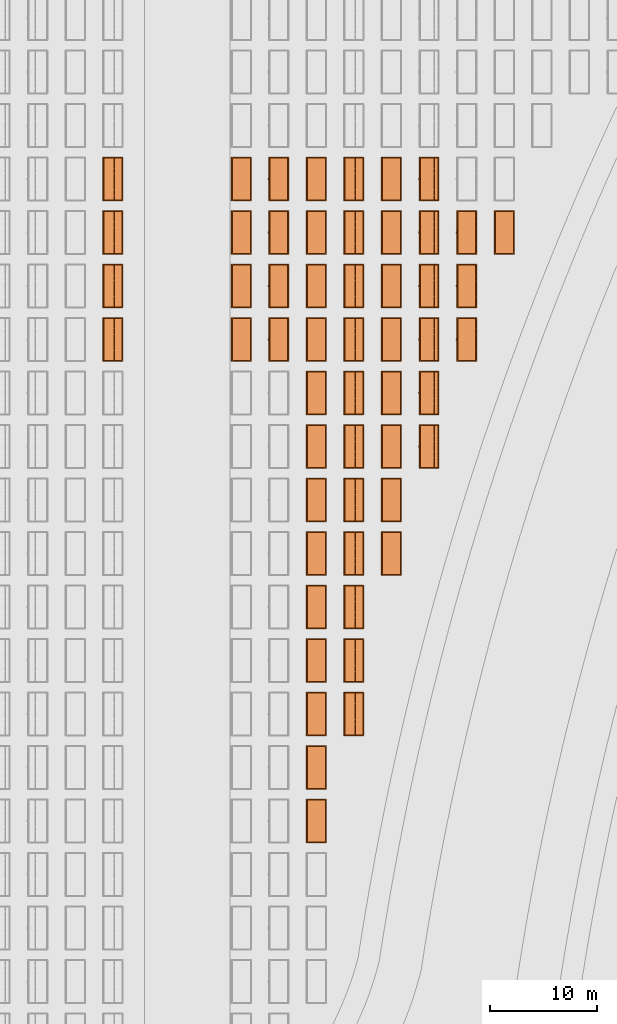
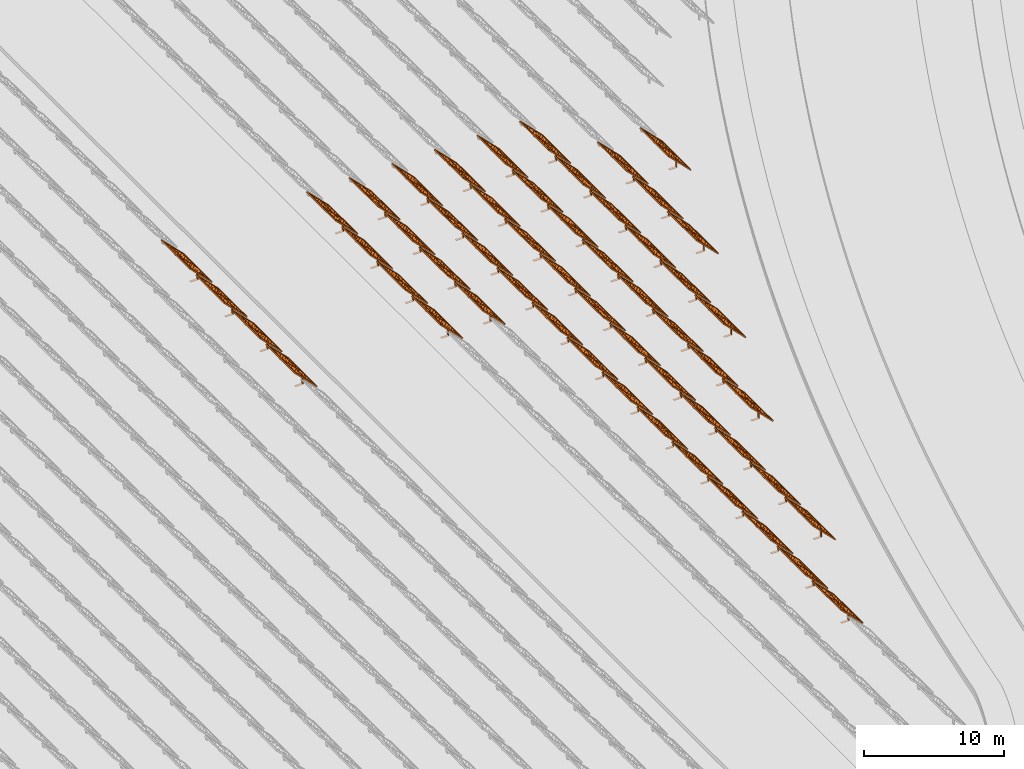
# One storey, part 26 of 39: 54 proxies.
"""IFC2X3 building model written with IfcOpenShell, lengths in millimetres."""

from ifc_helpers import new_model, entity, si_unit, converted_unit, derived_unit, direction, frame, frame_2d, origin, origin_2d_with_axis, place, context, subcontext, project, spatial, polyline, rectangle, outline, extrude, source, transform, mapped, material, material_list, element, save


model = new_model("IFC2X3")

# Units and contexts
model_context = context("Model", 3, precision=1e-06, world=origin(), true_north=direction((2.0, 6.12303176911189e-17, 1.0)))
context_of_model = context(None, 3, precision=1e-06, world=origin(), true_north=direction((2.0, 6.12303176911189e-17, 1.0)))
body_context = subcontext(model_context, "Body", "Model", "MODEL_VIEW")
ifc_project = project(units=[si_unit("LENGTHUNIT", "METRE", prefix="MILLI"), si_unit("AREAUNIT", "SQUARE_METRE", prefix="MILLI"), si_unit("VOLUMEUNIT", "CUBIC_METRE", prefix="MILLI"), converted_unit("PLANEANGLEUNIT", "DEGREE", entity("IfcRatioMeasure", 0.0174532925199433), si_unit("PLANEANGLEUNIT", "RADIAN"), dimensions=[0, 0, 0, 0, 0, 0, 0]), si_unit("MASSUNIT", "GRAM", prefix="KILO"), si_unit("TIMEUNIT", "SECOND"), si_unit("THERMODYNAMICTEMPERATUREUNIT", "KELVIN"), derived_unit("THERMALTRANSMITTANCEUNIT", [(si_unit("MASSUNIT", "GRAM", prefix="KILO"), 1), (si_unit("THERMODYNAMICTEMPERATUREUNIT", "KELVIN"), -1), (si_unit("TIMEUNIT", "SECOND"), -3)]), derived_unit("VOLUMETRICFLOWRATEUNIT", [(si_unit("LENGTHUNIT", "METRE"), 3), (si_unit("TIMEUNIT", "SECOND"), -1)])], contexts=[model_context, context_of_model])

# Site, building, storey
site_placement = place(None, origin())
site = spatial("IfcSite", under=ifc_project, at=site_placement, CompositionType="ELEMENT")
building_placement = place(site_placement, origin())
building = spatial("IfcBuilding", under=site, at=building_placement, CompositionType="ELEMENT")
storey_placement = place(building_placement, frame((0.0, 0.0, 4000.0)))
storey = spatial("IfcBuildingStorey", under=building, at=storey_placement, Name="Level 2", CompositionType="ELEMENT", Elevation=4000.0)

# Proxies
ifc_material_1 = material(Name="Stand-Steel")
ifc_material_2 = material(Name="Aluminium")
ifc_material_3 = material(Name="Glass")
ifc_material_list_1 = material_list([ifc_material_1, ifc_material_2, ifc_material_3])
shared_shape = source(origin(), body_context, "Body", "SweptSolid", [
    extrude(outline(polyline([(-629.526235435404, -220.0), (329.763117717702, -220.0), (329.763117717703, 410.0), (299.763117717703, 410.0), (299.763117717702, -190.0), (-629.526235435404, -190.0), (-629.526235435404, -220.0)])), frame((-190.00003127179, -100.0, 299.763117717707), z_axis=(0.0, 1.0, 0.0), x_axis=(0.0, 0.0, -1.0)), (0.0, 0.0, 1.0), 200.0),
    extrude(rectangle(XDim=20.0000000000001, YDim=200.0, at=frame_2d((0.0, -7.105427357601e-14), x_axis=(0.0, 1.0))), frame((-7.07109908365613, 0.0, 922.21828534124), z_axis=(-0.70710678118654, 0.0, 0.707106781186555), x_axis=(0.0, 1.0, 0.0)), (0.0, 0.0, 1.0), 2600.0),
    extrude(rectangle(XDim=24.9999999999997, YDim=24.9999999999999, at=frame_2d((2.87769807982841e-13, -9.50350909079134e-14), x_axis=(1.0, 0.0))), frame((-1449.56292018118, -1950.0, 2449.57494522722), z_axis=(0.0, 1.0, 0.0), x_axis=(-0.707106781186548, 0.0, -0.707106781186548)), (0.0, 0.0, 1.0), 3900.0),
    extrude(rectangle(XDim=24.9999999999999, YDim=25.0000000000001, at=origin_2d_with_axis()), frame((-1096.0095295879, -1950.0, 2096.02155463395), z_axis=(0.0, 1.0, 0.0), x_axis=(-0.707106781186542, 0.0, -0.707106781186553)), (0.0, 0.0, 1.0), 3900.0),
    extrude(rectangle(XDim=24.9999999999999, YDim=25.0000000000001, at=origin_2d_with_axis()), frame((-742.456138994631, -1950.0, 1742.46816404067), z_axis=(0.0, 1.0, 0.0), x_axis=(-0.707106781186542, 0.0, -0.707106781186553)), (0.0, 0.0, 1.0), 3900.0),
    extrude(rectangle(XDim=25.0, YDim=24.9999999999997, at=frame_2d((-7.19424519957101e-14, 1.19904086659517e-13), x_axis=(1.0, 0.0))), frame((-388.902748401358, -1950.0, 1388.9147734474), z_axis=(0.0, 1.0, 0.0), x_axis=(-0.707106781186545, 0.0, -0.70710678118655)), (0.0, 0.0, 1.0), 3900.0),
    extrude(rectangle(XDim=25.0000000000002, YDim=25.0, at=frame_2d((1.35891298214119e-13, 6.21724893790088e-15), x_axis=(0.0, 1.0))), frame((-35.3553703311048, 1500.0, 1035.35537033109), z_axis=(-0.707106781186544, 0.0, 0.707106781186551), x_axis=(0.0, 1.0, 0.0)), (0.0, 0.0, 1.0), 2440.0),
    extrude(rectangle(XDim=25.0000000000002, YDim=25.0, at=frame_2d((0.0, 1.77635683940025e-15), x_axis=(0.0, 1.0))), frame((-35.3553703311059, 1000.0, 1035.35537033109), z_axis=(-0.707106781186546, 0.0, 0.707106781186549), x_axis=(0.0, 1.0, 0.0)), (0.0, 0.0, 1.0), 2440.0),
    extrude(rectangle(XDim=25.0000000000002, YDim=25.0, at=frame_2d((0.0, 8.43769498715119e-14), x_axis=(0.0, 1.0))), frame((-26.5165355662756, 0.0, 1044.19420509593), z_axis=(-0.707106781186546, 0.0, 0.707106781186549), x_axis=(0.0, -1.0, 0.0)), (0.0, 0.0, 1.0), 2440.0),
    extrude(rectangle(XDim=25.0000000000002, YDim=25.0, at=frame_2d((0.0, 8.88178419700125e-16), x_axis=(0.0, 1.0))), frame((-35.3553703311065, 500.0, 1035.35537033109), z_axis=(-0.707106781186546, 0.0, 0.707106781186549), x_axis=(0.0, 1.0, 0.0)), (0.0, 0.0, 1.0), 2440.0),
    extrude(rectangle(XDim=25.0000000000002, YDim=25.0, at=frame_2d((0.0, 8.88178419700125e-16), x_axis=(0.0, 1.0))), frame((-35.3553703311086, -500.0, 1035.35537033109), z_axis=(-0.707106781186546, 0.0, 0.707106781186549), x_axis=(0.0, 1.0, 0.0)), (0.0, 0.0, 1.0), 2440.0),
    extrude(rectangle(XDim=25.0000000000002, YDim=25.0, at=frame_2d((0.0, 8.88178419700125e-16), x_axis=(0.0, 1.0))), frame((-35.3553703311095, -1000.0, 1035.35537033109), z_axis=(-0.707106781186546, 0.0, 0.707106781186549), x_axis=(0.0, 1.0, 0.0)), (0.0, 0.0, 1.0), 2440.0),
    extrude(rectangle(XDim=25.0000000000002, YDim=25.0, at=frame_2d((1.35891298214119e-13, 1.77635683940025e-15), x_axis=(0.0, 1.0))), frame((-35.3553703311107, -1500.0, 1035.35537033109), z_axis=(-0.707106781186546, 0.0, 0.707106781186549), x_axis=(0.0, 1.0, 0.0)), (0.0, 0.0, 1.0), 2440.0),
    extrude(rectangle(XDim=2400.0, YDim=11.9999999999994, at=frame_2d((-1.13686837721616e-13, 2.02948768901479e-13), x_axis=(1.0, 0.0))), frame((-883.883507754966, -1950.0, 1883.88350775495), z_axis=(0.0, 1.0, 0.0), x_axis=(0.707106781186546, 0.0, -0.707106781186549)), (0.0, 0.0, 1.0), 3900.0),
    extrude(outline(polyline([(-2050.0, -1300.0), (2050.0, -1300.0), (2050.0, 1300.0), (-2050.0, 1300.0), (-2050.0, -1300.0)]), holes=[polyline([(1950.0, -1200.0), (-1950.0, -1200.0), (-1950.0, 1200.0), (1950.0, 1200.0), (1950.0, -1200.0)])]), frame((-919.238846814293, 0.0, 1848.52816869563), z_axis=(0.707106781186554, 0.0, 0.707106781186541), x_axis=(0.0, 1.0, 0.0)), (0.0, 0.0, 1.0), 99.9999999999898),
])
proxy_1_placement = place(storey_placement, frame((-140870.317940101, 500144.680552409, 30.0)))
element("IfcBuildingElementProxy", 1, at=proxy_1_placement, inside=storey, material=ifc_material_list_1, Name="Solar Panel_4000X2500:Solar Panel_4000X2500", ObjectType="Solar Panel_4000X2500", CompositionType="ELEMENT", context=body_context, shape_type="MappedRepresentation", body=[
    mapped(shared_shape, transform((0.0, 0.0, 0.0), scale=1.0)),
])
ifc_material_list_2 = material_list([ifc_material_1, ifc_material_2, ifc_material_3])
proxy_2_placement = place(storey_placement, frame((-140870.317940101, 505144.680552409, 30.0)))
element("IfcBuildingElementProxy", 2, at=proxy_2_placement, inside=storey, material=ifc_material_list_2, Name="Solar Panel_4000X2500:Solar Panel_4000X2500", ObjectType="Solar Panel_4000X2500", CompositionType="ELEMENT", context=body_context, shape_type="MappedRepresentation", body=[
    mapped(shared_shape, transform((0.0, 0.0, 0.0), scale=1.0)),
])
ifc_material_list_3 = material_list([ifc_material_1, ifc_material_2, ifc_material_3])
proxy_3_placement = place(storey_placement, frame((-140870.317940101, 510144.680552409, 30.0)))
element("IfcBuildingElementProxy", 3, at=proxy_3_placement, inside=storey, material=ifc_material_list_3, Name="Solar Panel_4000X2500:Solar Panel_4000X2500", ObjectType="Solar Panel_4000X2500", CompositionType="ELEMENT", context=body_context, shape_type="MappedRepresentation", body=[
    mapped(shared_shape, transform((0.0, 0.0, 0.0), scale=1.0)),
])
ifc_material_list_4 = material_list([ifc_material_1, ifc_material_2, ifc_material_3])
proxy_4_placement = place(storey_placement, frame((-140870.317940101, 515144.680552409, 30.0)))
element("IfcBuildingElementProxy", 4, at=proxy_4_placement, inside=storey, material=ifc_material_list_4, Name="Solar Panel_4000X2500:Solar Panel_4000X2500", ObjectType="Solar Panel_4000X2500", CompositionType="ELEMENT", context=body_context, shape_type="MappedRepresentation", body=[
    mapped(shared_shape, transform((0.0, 0.0, 0.0), scale=1.0)),
])
ifc_material_list_5 = material_list([ifc_material_1, ifc_material_2, ifc_material_3])
proxy_5_placement = place(storey_placement, frame((-140870.317940101, 520144.680552409, 30.0)))
element("IfcBuildingElementProxy", 5, at=proxy_5_placement, inside=storey, material=ifc_material_list_5, Name="Solar Panel_4000X2500:Solar Panel_4000X2500", ObjectType="Solar Panel_4000X2500", CompositionType="ELEMENT", context=body_context, shape_type="MappedRepresentation", body=[
    mapped(shared_shape, transform((0.0, 0.0, 0.0), scale=1.0)),
])
ifc_material_list_6 = material_list([ifc_material_1, ifc_material_2, ifc_material_3])
proxy_6_placement = place(storey_placement, frame((-140870.317940101, 525144.680552409, 30.0)))
element("IfcBuildingElementProxy", 6, at=proxy_6_placement, inside=storey, material=ifc_material_list_6, Name="Solar Panel_4000X2500:Solar Panel_4000X2500", ObjectType="Solar Panel_4000X2500", CompositionType="ELEMENT", context=body_context, shape_type="MappedRepresentation", body=[
    mapped(shared_shape, transform((0.0, 0.0, 0.0), scale=1.0)),
])
ifc_material_list_7 = material_list([ifc_material_1, ifc_material_2, ifc_material_3])
proxy_7_placement = place(storey_placement, frame((-140870.317940101, 530144.680552408, 30.0)))
element("IfcBuildingElementProxy", 7, at=proxy_7_placement, inside=storey, material=ifc_material_list_7, Name="Solar Panel_4000X2500:Solar Panel_4000X2500", ObjectType="Solar Panel_4000X2500", CompositionType="ELEMENT", context=body_context, shape_type="MappedRepresentation", body=[
    mapped(shared_shape, transform((0.0, 0.0, 0.0), scale=1.0)),
])
ifc_material_list_8 = material_list([ifc_material_1, ifc_material_2, ifc_material_3])
proxy_8_placement = place(storey_placement, frame((-140870.317940101, 535144.680552408, 30.0)))
element("IfcBuildingElementProxy", 8, at=proxy_8_placement, inside=storey, material=ifc_material_list_8, Name="Solar Panel_4000X2500:Solar Panel_4000X2500", ObjectType="Solar Panel_4000X2500", CompositionType="ELEMENT", context=body_context, shape_type="MappedRepresentation", body=[
    mapped(shared_shape, transform((0.0, 0.0, 0.0), scale=1.0)),
])
ifc_material_list_9 = material_list([ifc_material_1, ifc_material_2, ifc_material_3])
proxy_9_placement = place(storey_placement, frame((-137355.307568371, 510144.680552409, 30.0)))
element("IfcBuildingElementProxy", 9, at=proxy_9_placement, inside=storey, material=ifc_material_list_9, Name="Solar Panel_4000X2500:Solar Panel_4000X2500", ObjectType="Solar Panel_4000X2500", CompositionType="ELEMENT", context=body_context, shape_type="MappedRepresentation", body=[
    mapped(shared_shape, transform((0.0, 0.0, 0.0), scale=1.0)),
])
ifc_material_list_10 = material_list([ifc_material_1, ifc_material_2, ifc_material_3])
proxy_10_placement = place(storey_placement, frame((-137355.307568371, 515144.680552409, 30.0)))
element("IfcBuildingElementProxy", 10, at=proxy_10_placement, inside=storey, material=ifc_material_list_10, Name="Solar Panel_4000X2500:Solar Panel_4000X2500", ObjectType="Solar Panel_4000X2500", CompositionType="ELEMENT", context=body_context, shape_type="MappedRepresentation", body=[
    mapped(shared_shape, transform((0.0, 0.0, 0.0), scale=1.0)),
])
ifc_material_list_11 = material_list([ifc_material_1, ifc_material_2, ifc_material_3])
proxy_11_placement = place(storey_placement, frame((-137355.307568371, 520144.680552409, 30.0)))
element("IfcBuildingElementProxy", 11, at=proxy_11_placement, inside=storey, material=ifc_material_list_11, Name="Solar Panel_4000X2500:Solar Panel_4000X2500", ObjectType="Solar Panel_4000X2500", CompositionType="ELEMENT", context=body_context, shape_type="MappedRepresentation", body=[
    mapped(shared_shape, transform((0.0, 0.0, 0.0), scale=1.0)),
])
ifc_material_list_12 = material_list([ifc_material_1, ifc_material_2, ifc_material_3])
proxy_12_placement = place(storey_placement, frame((-137355.307568371, 525144.680552409, 30.0)))
element("IfcBuildingElementProxy", 12, at=proxy_12_placement, inside=storey, material=ifc_material_list_12, Name="Solar Panel_4000X2500:Solar Panel_4000X2500", ObjectType="Solar Panel_4000X2500", CompositionType="ELEMENT", context=body_context, shape_type="MappedRepresentation", body=[
    mapped(shared_shape, transform((0.0, 0.0, 0.0), scale=1.0)),
])
ifc_material_list_13 = material_list([ifc_material_1, ifc_material_2, ifc_material_3])
proxy_13_placement = place(storey_placement, frame((-137355.307568371, 530144.680552408, 30.0)))
element("IfcBuildingElementProxy", 13, at=proxy_13_placement, inside=storey, material=ifc_material_list_13, Name="Solar Panel_4000X2500:Solar Panel_4000X2500", ObjectType="Solar Panel_4000X2500", CompositionType="ELEMENT", context=body_context, shape_type="MappedRepresentation", body=[
    mapped(shared_shape, transform((0.0, 0.0, 0.0), scale=1.0)),
])
ifc_material_list_14 = material_list([ifc_material_1, ifc_material_2, ifc_material_3])
proxy_14_placement = place(storey_placement, frame((-137355.307568371, 535144.680552408, 30.0)))
element("IfcBuildingElementProxy", 14, at=proxy_14_placement, inside=storey, material=ifc_material_list_14, Name="Solar Panel_4000X2500:Solar Panel_4000X2500", ObjectType="Solar Panel_4000X2500", CompositionType="ELEMENT", context=body_context, shape_type="MappedRepresentation", body=[
    mapped(shared_shape, transform((0.0, 0.0, 0.0), scale=1.0)),
])
ifc_material_list_15 = material_list([ifc_material_1, ifc_material_2, ifc_material_3])
proxy_15_placement = place(storey_placement, frame((-133840.297196641, 525144.680552409, 30.0)))
element("IfcBuildingElementProxy", 15, at=proxy_15_placement, inside=storey, material=ifc_material_list_15, Name="Solar Panel_4000X2500:Solar Panel_4000X2500", ObjectType="Solar Panel_4000X2500", CompositionType="ELEMENT", context=body_context, shape_type="MappedRepresentation", body=[
    mapped(shared_shape, transform((0.0, 0.0, 0.0), scale=1.0)),
])
ifc_material_list_16 = material_list([ifc_material_1, ifc_material_2, ifc_material_3])
proxy_16_placement = place(storey_placement, frame((-133840.297196641, 530144.680552408, 30.0)))
element("IfcBuildingElementProxy", 16, at=proxy_16_placement, inside=storey, material=ifc_material_list_16, Name="Solar Panel_4000X2500:Solar Panel_4000X2500", ObjectType="Solar Panel_4000X2500", CompositionType="ELEMENT", context=body_context, shape_type="MappedRepresentation", body=[
    mapped(shared_shape, transform((0.0, 0.0, 0.0), scale=1.0)),
])
ifc_material_list_17 = material_list([ifc_material_1, ifc_material_2, ifc_material_3])
proxy_17_placement = place(storey_placement, frame((-133840.297196641, 535144.680552408, 30.0)))
element("IfcBuildingElementProxy", 17, at=proxy_17_placement, inside=storey, material=ifc_material_list_17, Name="Solar Panel_4000X2500:Solar Panel_4000X2500", ObjectType="Solar Panel_4000X2500", CompositionType="ELEMENT", context=body_context, shape_type="MappedRepresentation", body=[
    mapped(shared_shape, transform((0.0, 0.0, 0.0), scale=1.0)),
])
ifc_material_list_18 = material_list([ifc_material_1, ifc_material_2, ifc_material_3])
proxy_18_placement = place(storey_placement, frame((-130325.286824911, 535144.680552408, 30.0)))
element("IfcBuildingElementProxy", 18, at=proxy_18_placement, inside=storey, material=ifc_material_list_18, Name="Solar Panel_4000X2500:Solar Panel_4000X2500", ObjectType="Solar Panel_4000X2500", CompositionType="ELEMENT", context=body_context, shape_type="MappedRepresentation", body=[
    mapped(shared_shape, transform((0.0, 0.0, 0.0), scale=1.0)),
])
ifc_material_list_19 = material_list([ifc_material_1, ifc_material_2, ifc_material_3])
proxy_19_placement = place(storey_placement, frame((-140870.317940101, 540144.680552408, 30.0)))
element("IfcBuildingElementProxy", 19, at=proxy_19_placement, inside=storey, material=ifc_material_list_19, Name="Solar Panel_4000X2500:Solar Panel_4000X2500", ObjectType="Solar Panel_4000X2500", CompositionType="ELEMENT", context=body_context, shape_type="MappedRepresentation", body=[
    mapped(shared_shape, transform((0.0, 0.0, 0.0), scale=1.0)),
])
ifc_material_list_20 = material_list([ifc_material_1, ifc_material_2, ifc_material_3])
proxy_20_placement = place(storey_placement, frame((-137355.307568371, 540144.680552408, 30.0)))
element("IfcBuildingElementProxy", 20, at=proxy_20_placement, inside=storey, material=ifc_material_list_20, Name="Solar Panel_4000X2500:Solar Panel_4000X2500", ObjectType="Solar Panel_4000X2500", CompositionType="ELEMENT", context=body_context, shape_type="MappedRepresentation", body=[
    mapped(shared_shape, transform((0.0, 0.0, 0.0), scale=1.0)),
])
ifc_material_list_21 = material_list([ifc_material_1, ifc_material_2, ifc_material_3])
proxy_21_placement = place(storey_placement, frame((-133840.297196641, 540144.680552408, 30.0)))
element("IfcBuildingElementProxy", 21, at=proxy_21_placement, inside=storey, material=ifc_material_list_21, Name="Solar Panel_4000X2500:Solar Panel_4000X2500", ObjectType="Solar Panel_4000X2500", CompositionType="ELEMENT", context=body_context, shape_type="MappedRepresentation", body=[
    mapped(shared_shape, transform((0.0, 0.0, 0.0), scale=1.0)),
])
ifc_material_list_22 = material_list([ifc_material_1, ifc_material_2, ifc_material_3])
proxy_22_placement = place(storey_placement, frame((-130325.286824911, 540144.680552408, 30.0)))
element("IfcBuildingElementProxy", 22, at=proxy_22_placement, inside=storey, material=ifc_material_list_22, Name="Solar Panel_4000X2500:Solar Panel_4000X2500", ObjectType="Solar Panel_4000X2500", CompositionType="ELEMENT", context=body_context, shape_type="MappedRepresentation", body=[
    mapped(shared_shape, transform((0.0, 0.0, 0.0), scale=1.0)),
])
ifc_material_list_23 = material_list([ifc_material_1, ifc_material_2, ifc_material_3])
proxy_23_placement = place(storey_placement, frame((-140870.317940101, 545144.680552408, 30.0)))
element("IfcBuildingElementProxy", 23, at=proxy_23_placement, inside=storey, material=ifc_material_list_23, Name="Solar Panel_4000X2500:Solar Panel_4000X2500", ObjectType="Solar Panel_4000X2500", CompositionType="ELEMENT", context=body_context, shape_type="MappedRepresentation", body=[
    mapped(shared_shape, transform((0.0, 0.0, 0.0), scale=1.0)),
])
ifc_material_list_24 = material_list([ifc_material_1, ifc_material_2, ifc_material_3])
proxy_24_placement = place(storey_placement, frame((-137355.307568371, 545144.680552408, 30.0)))
element("IfcBuildingElementProxy", 24, at=proxy_24_placement, inside=storey, material=ifc_material_list_24, Name="Solar Panel_4000X2500:Solar Panel_4000X2500", ObjectType="Solar Panel_4000X2500", CompositionType="ELEMENT", context=body_context, shape_type="MappedRepresentation", body=[
    mapped(shared_shape, transform((0.0, 0.0, 0.0), scale=1.0)),
])
ifc_material_list_25 = material_list([ifc_material_1, ifc_material_2, ifc_material_3])
proxy_25_placement = place(storey_placement, frame((-133840.297196641, 545144.680552408, 30.0)))
element("IfcBuildingElementProxy", 25, at=proxy_25_placement, inside=storey, material=ifc_material_list_25, Name="Solar Panel_4000X2500:Solar Panel_4000X2500", ObjectType="Solar Panel_4000X2500", CompositionType="ELEMENT", context=body_context, shape_type="MappedRepresentation", body=[
    mapped(shared_shape, transform((0.0, 0.0, 0.0), scale=1.0)),
])
ifc_material_list_26 = material_list([ifc_material_1, ifc_material_2, ifc_material_3])
proxy_26_placement = place(storey_placement, frame((-130325.286824911, 545144.680552408, 30.0)))
element("IfcBuildingElementProxy", 26, at=proxy_26_placement, inside=storey, material=ifc_material_list_26, Name="Solar Panel_4000X2500:Solar Panel_4000X2500", ObjectType="Solar Panel_4000X2500", CompositionType="ELEMENT", context=body_context, shape_type="MappedRepresentation", body=[
    mapped(shared_shape, transform((0.0, 0.0, 0.0), scale=1.0)),
])
ifc_material_list_27 = material_list([ifc_material_1, ifc_material_2, ifc_material_3])
proxy_27_placement = place(storey_placement, frame((-140870.317940101, 550144.680552408, 30.0)))
element("IfcBuildingElementProxy", 27, at=proxy_27_placement, inside=storey, material=ifc_material_list_27, Name="Solar Panel_4000X2500:Solar Panel_4000X2500", ObjectType="Solar Panel_4000X2500", CompositionType="ELEMENT", context=body_context, shape_type="MappedRepresentation", body=[
    mapped(shared_shape, transform((0.0, 0.0, 0.0), scale=1.0)),
])
ifc_material_list_28 = material_list([ifc_material_1, ifc_material_2, ifc_material_3])
proxy_28_placement = place(storey_placement, frame((-137355.307568371, 550144.680552408, 30.0)))
element("IfcBuildingElementProxy", 28, at=proxy_28_placement, inside=storey, material=ifc_material_list_28, Name="Solar Panel_4000X2500:Solar Panel_4000X2500", ObjectType="Solar Panel_4000X2500", CompositionType="ELEMENT", context=body_context, shape_type="MappedRepresentation", body=[
    mapped(shared_shape, transform((0.0, 0.0, 0.0), scale=1.0)),
])
ifc_material_list_29 = material_list([ifc_material_1, ifc_material_2, ifc_material_3])
proxy_29_placement = place(storey_placement, frame((-133840.297196641, 550144.680552408, 30.0)))
element("IfcBuildingElementProxy", 29, at=proxy_29_placement, inside=storey, material=ifc_material_list_29, Name="Solar Panel_4000X2500:Solar Panel_4000X2500", ObjectType="Solar Panel_4000X2500", CompositionType="ELEMENT", context=body_context, shape_type="MappedRepresentation", body=[
    mapped(shared_shape, transform((0.0, 0.0, 0.0), scale=1.0)),
])
ifc_material_list_30 = material_list([ifc_material_1, ifc_material_2, ifc_material_3])
proxy_30_placement = place(storey_placement, frame((-130325.286824911, 550144.680552408, 30.0)))
element("IfcBuildingElementProxy", 30, at=proxy_30_placement, inside=storey, material=ifc_material_list_30, Name="Solar Panel_4000X2500:Solar Panel_4000X2500", ObjectType="Solar Panel_4000X2500", CompositionType="ELEMENT", context=body_context, shape_type="MappedRepresentation", body=[
    mapped(shared_shape, transform((0.0, 0.0, 0.0), scale=1.0)),
])
ifc_material_list_31 = material_list([ifc_material_1, ifc_material_2, ifc_material_3])
proxy_31_placement = place(storey_placement, frame((-140870.317940101, 555144.680552408, 30.0)))
element("IfcBuildingElementProxy", 31, at=proxy_31_placement, inside=storey, material=ifc_material_list_31, Name="Solar Panel_4000X2500:Solar Panel_4000X2500", ObjectType="Solar Panel_4000X2500", CompositionType="ELEMENT", context=body_context, shape_type="MappedRepresentation", body=[
    mapped(shared_shape, transform((0.0, 0.0, 0.0), scale=1.0)),
])
ifc_material_list_32 = material_list([ifc_material_1, ifc_material_2, ifc_material_3])
proxy_32_placement = place(storey_placement, frame((-137355.307568371, 555144.680552408, 30.0)))
element("IfcBuildingElementProxy", 32, at=proxy_32_placement, inside=storey, material=ifc_material_list_32, Name="Solar Panel_4000X2500:Solar Panel_4000X2500", ObjectType="Solar Panel_4000X2500", CompositionType="ELEMENT", context=body_context, shape_type="MappedRepresentation", body=[
    mapped(shared_shape, transform((0.0, 0.0, 0.0), scale=1.0)),
])
ifc_material_list_33 = material_list([ifc_material_1, ifc_material_2, ifc_material_3])
proxy_33_placement = place(storey_placement, frame((-133840.297196641, 555144.680552408, 30.0)))
element("IfcBuildingElementProxy", 33, at=proxy_33_placement, inside=storey, material=ifc_material_list_33, Name="Solar Panel_4000X2500:Solar Panel_4000X2500", ObjectType="Solar Panel_4000X2500", CompositionType="ELEMENT", context=body_context, shape_type="MappedRepresentation", body=[
    mapped(shared_shape, transform((0.0, 0.0, 0.0), scale=1.0)),
])
ifc_material_list_34 = material_list([ifc_material_1, ifc_material_2, ifc_material_3])
proxy_34_placement = place(storey_placement, frame((-130325.286824911, 555144.680552408, 30.0)))
element("IfcBuildingElementProxy", 34, at=proxy_34_placement, inside=storey, material=ifc_material_list_34, Name="Solar Panel_4000X2500:Solar Panel_4000X2500", ObjectType="Solar Panel_4000X2500", CompositionType="ELEMENT", context=body_context, shape_type="MappedRepresentation", body=[
    mapped(shared_shape, transform((0.0, 0.0, 0.0), scale=1.0)),
])
ifc_material_list_35 = material_list([ifc_material_1, ifc_material_2, ifc_material_3])
proxy_35_placement = place(storey_placement, frame((-140870.317940101, 560144.680552408, 30.0)))
element("IfcBuildingElementProxy", 35, at=proxy_35_placement, inside=storey, material=ifc_material_list_35, Name="Solar Panel_4000X2500:Solar Panel_4000X2500", ObjectType="Solar Panel_4000X2500", CompositionType="ELEMENT", context=body_context, shape_type="MappedRepresentation", body=[
    mapped(shared_shape, transform((0.0, 0.0, 0.0), scale=1.0)),
])
ifc_material_list_36 = material_list([ifc_material_1, ifc_material_2, ifc_material_3])
proxy_36_placement = place(storey_placement, frame((-137355.307568371, 560144.680552408, 30.0)))
element("IfcBuildingElementProxy", 36, at=proxy_36_placement, inside=storey, material=ifc_material_list_36, Name="Solar Panel_4000X2500:Solar Panel_4000X2500", ObjectType="Solar Panel_4000X2500", CompositionType="ELEMENT", context=body_context, shape_type="MappedRepresentation", body=[
    mapped(shared_shape, transform((0.0, 0.0, 0.0), scale=1.0)),
])
ifc_material_list_37 = material_list([ifc_material_1, ifc_material_2, ifc_material_3])
proxy_37_placement = place(storey_placement, frame((-133840.297196641, 560144.680552408, 30.0)))
element("IfcBuildingElementProxy", 37, at=proxy_37_placement, inside=storey, material=ifc_material_list_37, Name="Solar Panel_4000X2500:Solar Panel_4000X2500", ObjectType="Solar Panel_4000X2500", CompositionType="ELEMENT", context=body_context, shape_type="MappedRepresentation", body=[
    mapped(shared_shape, transform((0.0, 0.0, 0.0), scale=1.0)),
])
ifc_material_list_38 = material_list([ifc_material_1, ifc_material_2, ifc_material_3])
proxy_38_placement = place(storey_placement, frame((-130325.286824911, 560144.680552408, 30.0)))
element("IfcBuildingElementProxy", 38, at=proxy_38_placement, inside=storey, material=ifc_material_list_38, Name="Solar Panel_4000X2500:Solar Panel_4000X2500", ObjectType="Solar Panel_4000X2500", CompositionType="ELEMENT", context=body_context, shape_type="MappedRepresentation", body=[
    mapped(shared_shape, transform((0.0, 0.0, 0.0), scale=1.0)),
])
ifc_material_list_39 = material_list([ifc_material_1, ifc_material_2, ifc_material_3])
proxy_39_placement = place(storey_placement, frame((-126810.276453181, 545144.680552408, 30.0)))
element("IfcBuildingElementProxy", 39, at=proxy_39_placement, inside=storey, material=ifc_material_list_39, Name="Solar Panel_4000X2500:Solar Panel_4000X2500", ObjectType="Solar Panel_4000X2500", CompositionType="ELEMENT", context=body_context, shape_type="MappedRepresentation", body=[
    mapped(shared_shape, transform((0.0, 0.0, 0.0), scale=1.0)),
])
ifc_material_list_40 = material_list([ifc_material_1, ifc_material_2, ifc_material_3])
proxy_40_placement = place(storey_placement, frame((-126810.276453181, 550144.680552408, 30.0)))
element("IfcBuildingElementProxy", 40, at=proxy_40_placement, inside=storey, material=ifc_material_list_40, Name="Solar Panel_4000X2500:Solar Panel_4000X2500", ObjectType="Solar Panel_4000X2500", CompositionType="ELEMENT", context=body_context, shape_type="MappedRepresentation", body=[
    mapped(shared_shape, transform((0.0, 0.0, 0.0), scale=1.0)),
])
ifc_material_list_41 = material_list([ifc_material_1, ifc_material_2, ifc_material_3])
proxy_41_placement = place(storey_placement, frame((-126810.276453181, 555144.680552408, 30.0)))
element("IfcBuildingElementProxy", 41, at=proxy_41_placement, inside=storey, material=ifc_material_list_41, Name="Solar Panel_4000X2500:Solar Panel_4000X2500", ObjectType="Solar Panel_4000X2500", CompositionType="ELEMENT", context=body_context, shape_type="MappedRepresentation", body=[
    mapped(shared_shape, transform((0.0, 0.0, 0.0), scale=1.0)),
])
ifc_material_list_42 = material_list([ifc_material_1, ifc_material_2, ifc_material_3])
proxy_42_placement = place(storey_placement, frame((-123295.266081452, 555144.680552408, 30.0)))
element("IfcBuildingElementProxy", 42, at=proxy_42_placement, inside=storey, material=ifc_material_list_42, Name="Solar Panel_4000X2500:Solar Panel_4000X2500", ObjectType="Solar Panel_4000X2500", CompositionType="ELEMENT", context=body_context, shape_type="MappedRepresentation", body=[
    mapped(shared_shape, transform((0.0, 0.0, 0.0), scale=1.0)),
])
ifc_material_list_43 = material_list([ifc_material_1, ifc_material_2, ifc_material_3])
proxy_43_placement = place(storey_placement, frame((-144385.32831183, 545144.680552408, 30.0)))
element("IfcBuildingElementProxy", 43, at=proxy_43_placement, inside=storey, material=ifc_material_list_43, Name="Solar Panel_4000X2500:Solar Panel_4000X2500", ObjectType="Solar Panel_4000X2500", CompositionType="ELEMENT", context=body_context, shape_type="MappedRepresentation", body=[
    mapped(shared_shape, transform((0.0, 0.0, 0.0), scale=1.0)),
])
ifc_material_list_44 = material_list([ifc_material_1, ifc_material_2, ifc_material_3])
proxy_44_placement = place(storey_placement, frame((-144385.32831183, 550144.680552408, 30.0)))
element("IfcBuildingElementProxy", 44, at=proxy_44_placement, inside=storey, material=ifc_material_list_44, Name="Solar Panel_4000X2500:Solar Panel_4000X2500", ObjectType="Solar Panel_4000X2500", CompositionType="ELEMENT", context=body_context, shape_type="MappedRepresentation", body=[
    mapped(shared_shape, transform((0.0, 0.0, 0.0), scale=1.0)),
])
ifc_material_list_45 = material_list([ifc_material_1, ifc_material_2, ifc_material_3])
proxy_45_placement = place(storey_placement, frame((-144385.32831183, 555144.680552408, 30.0)))
element("IfcBuildingElementProxy", 45, at=proxy_45_placement, inside=storey, material=ifc_material_list_45, Name="Solar Panel_4000X2500:Solar Panel_4000X2500", ObjectType="Solar Panel_4000X2500", CompositionType="ELEMENT", context=body_context, shape_type="MappedRepresentation", body=[
    mapped(shared_shape, transform((0.0, 0.0, 0.0), scale=1.0)),
])
ifc_material_list_46 = material_list([ifc_material_1, ifc_material_2, ifc_material_3])
proxy_46_placement = place(storey_placement, frame((-144385.32831183, 560144.680552408, 30.0)))
element("IfcBuildingElementProxy", 46, at=proxy_46_placement, inside=storey, material=ifc_material_list_46, Name="Solar Panel_4000X2500:Solar Panel_4000X2500", ObjectType="Solar Panel_4000X2500", CompositionType="ELEMENT", context=body_context, shape_type="MappedRepresentation", body=[
    mapped(shared_shape, transform((0.0, 0.0, 0.0), scale=1.0)),
])
ifc_material_list_47 = material_list([ifc_material_1, ifc_material_2, ifc_material_3])
proxy_47_placement = place(storey_placement, frame((-147885.32831183, 545144.680552408, 30.0)))
element("IfcBuildingElementProxy", 47, at=proxy_47_placement, inside=storey, material=ifc_material_list_47, Name="Solar Panel_4000X2500:Solar Panel_4000X2500", ObjectType="Solar Panel_4000X2500", CompositionType="ELEMENT", context=body_context, shape_type="MappedRepresentation", body=[
    mapped(shared_shape, transform((0.0, 0.0, 0.0), scale=1.0)),
])
ifc_material_list_48 = material_list([ifc_material_1, ifc_material_2, ifc_material_3])
proxy_48_placement = place(storey_placement, frame((-147885.32831183, 550144.680552408, 30.0)))
element("IfcBuildingElementProxy", 48, at=proxy_48_placement, inside=storey, material=ifc_material_list_48, Name="Solar Panel_4000X2500:Solar Panel_4000X2500", ObjectType="Solar Panel_4000X2500", CompositionType="ELEMENT", context=body_context, shape_type="MappedRepresentation", body=[
    mapped(shared_shape, transform((0.0, 0.0, 0.0), scale=1.0)),
])
ifc_material_list_49 = material_list([ifc_material_1, ifc_material_2, ifc_material_3])
proxy_49_placement = place(storey_placement, frame((-147885.32831183, 555144.680552408, 30.0)))
element("IfcBuildingElementProxy", 49, at=proxy_49_placement, inside=storey, material=ifc_material_list_49, Name="Solar Panel_4000X2500:Solar Panel_4000X2500", ObjectType="Solar Panel_4000X2500", CompositionType="ELEMENT", context=body_context, shape_type="MappedRepresentation", body=[
    mapped(shared_shape, transform((0.0, 0.0, 0.0), scale=1.0)),
])
ifc_material_list_50 = material_list([ifc_material_1, ifc_material_2, ifc_material_3])
proxy_50_placement = place(storey_placement, frame((-147885.32831183, 560144.680552408, 30.0)))
element("IfcBuildingElementProxy", 50, at=proxy_50_placement, inside=storey, material=ifc_material_list_50, Name="Solar Panel_4000X2500:Solar Panel_4000X2500", ObjectType="Solar Panel_4000X2500", CompositionType="ELEMENT", context=body_context, shape_type="MappedRepresentation", body=[
    mapped(shared_shape, transform((0.0, 0.0, 0.0), scale=1.0)),
])
ifc_material_list_51 = material_list([ifc_material_1, ifc_material_2, ifc_material_3])
proxy_51_placement = place(storey_placement, frame((-159885.32831183, 545144.680552408, 30.0)))
element("IfcBuildingElementProxy", 51, at=proxy_51_placement, inside=storey, material=ifc_material_list_51, Name="Solar Panel_4000X2500:Solar Panel_4000X2500", ObjectType="Solar Panel_4000X2500", CompositionType="ELEMENT", context=body_context, shape_type="MappedRepresentation", body=[
    mapped(shared_shape, transform((0.0, 0.0, 0.0), scale=1.0)),
])
ifc_material_list_52 = material_list([ifc_material_1, ifc_material_2, ifc_material_3])
proxy_52_placement = place(storey_placement, frame((-159885.32831183, 550144.680552408, 30.0)))
element("IfcBuildingElementProxy", 52, at=proxy_52_placement, inside=storey, material=ifc_material_list_52, Name="Solar Panel_4000X2500:Solar Panel_4000X2500", ObjectType="Solar Panel_4000X2500", CompositionType="ELEMENT", context=body_context, shape_type="MappedRepresentation", body=[
    mapped(shared_shape, transform((0.0, 0.0, 0.0), scale=1.0)),
])
ifc_material_list_53 = material_list([ifc_material_1, ifc_material_2, ifc_material_3])
proxy_53_placement = place(storey_placement, frame((-159885.32831183, 555144.680552408, 30.0)))
element("IfcBuildingElementProxy", 53, at=proxy_53_placement, inside=storey, material=ifc_material_list_53, Name="Solar Panel_4000X2500:Solar Panel_4000X2500", ObjectType="Solar Panel_4000X2500", CompositionType="ELEMENT", context=body_context, shape_type="MappedRepresentation", body=[
    mapped(shared_shape, transform((0.0, 0.0, 0.0), scale=1.0)),
])
ifc_material_list_54 = material_list([ifc_material_1, ifc_material_2, ifc_material_3])
proxy_54_placement = place(storey_placement, frame((-159885.32831183, 560144.680552408, 30.0)))
element("IfcBuildingElementProxy", 54, at=proxy_54_placement, inside=storey, material=ifc_material_list_54, Name="Solar Panel_4000X2500:Solar Panel_4000X2500", ObjectType="Solar Panel_4000X2500", CompositionType="ELEMENT", context=body_context, shape_type="MappedRepresentation", body=[
    mapped(shared_shape, transform((0.0, 0.0, 0.0), scale=1.0)),
])

save(model, "model.ifc")
